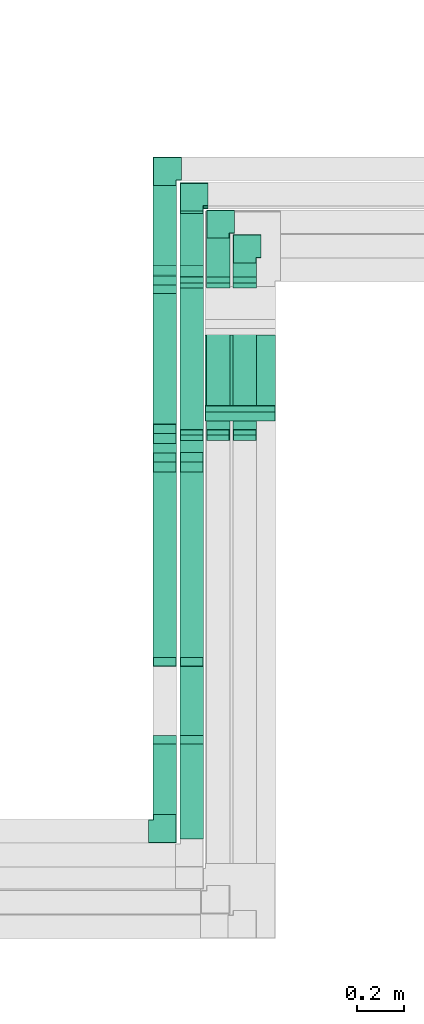
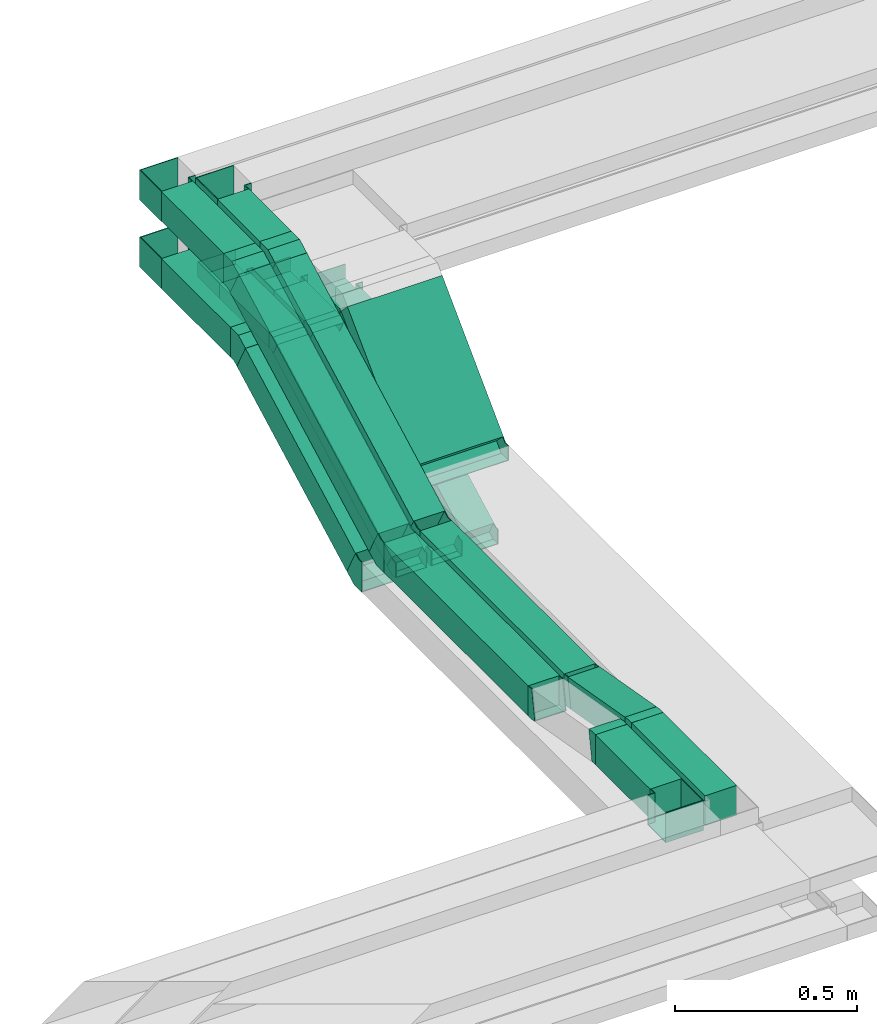
# One storey, part 11 of 18: 24 flow fittings, 18 flow segments.
"""IFC2X3 building model written with IfcOpenShell, lengths in millimetres."""

from ifc_helpers import new_model, entity, si_unit, converted_unit, derived_unit, direction, frame, frame_2d, origin, origin_2d_with_axis, place, context, subcontext, project, spatial, rectangle, extrude, faceted_brep, source, transform, mapped, material, type_object, type_shapes, element, save


model = new_model("IFC2X3")

# Units and contexts
model_context = context("Model", 3, precision=0.01, world=origin(), true_north=direction((6.12303176911189e-17, 1.0)))
body_context = subcontext(model_context, "Body", "Model", "MODEL_VIEW")
ifc_project = project(units=[si_unit("LENGTHUNIT", "METRE", prefix="MILLI"), si_unit("AREAUNIT", "SQUARE_METRE"), si_unit("VOLUMEUNIT", "CUBIC_METRE"), converted_unit("PLANEANGLEUNIT", "DEGREE", entity("IfcRatioMeasure", 0.0174532925199433), si_unit("PLANEANGLEUNIT", "RADIAN"), dimensions=[0, 0, 0, 0, 0, 0, 0]), si_unit("MASSUNIT", "GRAM", prefix="KILO"), derived_unit("MASSDENSITYUNIT", [(si_unit("MASSUNIT", "GRAM", prefix="KILO"), 1), (si_unit("LENGTHUNIT", "METRE"), -3)]), derived_unit("MOMENTOFINERTIAUNIT", [(si_unit("LENGTHUNIT", "METRE"), 4)]), si_unit("TIMEUNIT", "SECOND"), si_unit("FREQUENCYUNIT", "HERTZ"), si_unit("THERMODYNAMICTEMPERATUREUNIT", "DEGREE_CELSIUS"), derived_unit("THERMALTRANSMITTANCEUNIT", [(si_unit("MASSUNIT", "GRAM", prefix="KILO"), 1), (si_unit("THERMODYNAMICTEMPERATUREUNIT", "KELVIN"), -1), (si_unit("TIMEUNIT", "SECOND"), -3)]), derived_unit("VOLUMETRICFLOWRATEUNIT", [(si_unit("LENGTHUNIT", "METRE"), 3), (si_unit("TIMEUNIT", "SECOND"), -1)]), derived_unit("MASSFLOWRATEUNIT", [(si_unit("MASSUNIT", "GRAM", prefix="KILO"), 1), (si_unit("TIMEUNIT", "SECOND"), -1)]), derived_unit("ROTATIONALFREQUENCYUNIT", [(si_unit("TIMEUNIT", "SECOND"), -1)]), si_unit("ELECTRICCURRENTUNIT", "AMPERE"), si_unit("ELECTRICVOLTAGEUNIT", "VOLT"), si_unit("POWERUNIT", "WATT"), si_unit("FORCEUNIT", "NEWTON", prefix="KILO"), si_unit("ILLUMINANCEUNIT", "LUX"), si_unit("LUMINOUSFLUXUNIT", "LUMEN"), si_unit("LUMINOUSINTENSITYUNIT", "CANDELA"), derived_unit("USERDEFINED", [(si_unit("MASSUNIT", "GRAM", prefix="KILO"), -1), (si_unit("LENGTHUNIT", "METRE"), -2), (si_unit("TIMEUNIT", "SECOND"), 3), (si_unit("LUMINOUSFLUXUNIT", "LUMEN"), 1)]), derived_unit("LINEARVELOCITYUNIT", [(si_unit("LENGTHUNIT", "METRE"), 1), (si_unit("TIMEUNIT", "SECOND"), -1)]), si_unit("PRESSUREUNIT", "PASCAL"), derived_unit("USERDEFINED", [(si_unit("LENGTHUNIT", "METRE"), -2), (si_unit("MASSUNIT", "GRAM", prefix="KILO"), 1), (si_unit("TIMEUNIT", "SECOND"), -2)]), derived_unit("LINEARFORCEUNIT", [(si_unit("MASSUNIT", "GRAM", prefix="KILO"), 1), (si_unit("LENGTHUNIT", "METRE"), 1), (si_unit("TIMEUNIT", "SECOND"), -2), (si_unit("LENGTHUNIT", "METRE"), -1)]), derived_unit("PLANARFORCEUNIT", [(si_unit("MASSUNIT", "GRAM", prefix="KILO"), 1), (si_unit("LENGTHUNIT", "METRE"), 1), (si_unit("TIMEUNIT", "SECOND"), -2), (si_unit("LENGTHUNIT", "METRE"), -2)])], contexts=[model_context])

# Site, building, storey
site_placement = place(None, frame((0.0, -0.00077364408347762, 0.0)))
site = spatial("IfcSite", under=ifc_project, at=site_placement, CompositionType="ELEMENT")
building_placement = place(site_placement, origin())
building = spatial("IfcBuilding", under=site, at=building_placement, CompositionType="ELEMENT")
storey_placement = place(building_placement, frame((0.0, 0.0, 19800.0)))
storey = spatial("IfcBuildingStorey", under=building, at=storey_placement, CompositionType="ELEMENT", Elevation=19800.0)

# Flow segments
cable_carrier_segment_type = type_object("IfcCableCarrierSegmentType", PredefinedType="CABLETRAYSEGMENT")
flow_segment_1_placement = place(storey_placement, frame((45595.1221386505, 8738.57726519395, 2760.53094745423)))
element("IfcFlowSegment", 1, at=flow_segment_1_placement, inside=storey, type_object=cable_carrier_segment_type, context=body_context, shape_type="SweptSolid", body=[
    extrude(rectangle(XDim=100.000000000004, YDim=99.9999999999946, at=frame_2d((-2.59348098552437e-13, 0.0), x_axis=(1.0, 0.0))), frame((50.0, 23.4967105796033, 44.1350721302065), z_axis=(0.0, 0.882701442604095, 0.469934211592058), x_axis=(0.0, -0.469934211592058, 0.882701442604095)), (0.0, 0.0, 1.0), 863.244153807607),
])
flow_segment_2_placement = place(storey_placement, frame((45595.1221386505, 7913.71235144538, 2740.0)))
element("IfcFlowSegment", 2, at=flow_segment_2_placement, inside=storey, type_object=cable_carrier_segment_type, context=body_context, shape_type="SweptSolid", body=[
    extrude(rectangle(XDim=789.605024897989, YDim=99.9999999999946, at=frame_2d((5.40012479177676e-13, 0.0), x_axis=(1.0, 0.0))), frame((50.0, 394.802512448994, 0.0), z_axis=(0.0, 0.0, 1.0), x_axis=(0.0, 1.0, 0.0)), (0.0, 0.0, 1.0), 100.000000000003),
])
flow_segment_3_placement = place(storey_placement, frame((45595.1221386505, 7245.0, 2800.0)))
element("IfcFlowSegment", 3, at=flow_segment_3_placement, inside=storey, type_object=cable_carrier_segment_type, context=body_context, shape_type="SweptSolid", body=[
    extrude(rectangle(XDim=300.062822927531, YDim=99.9999999999946, at=frame_2d((0.0, -4.33075797445781e-12), x_axis=(1.0, 0.0))), frame((50.0, 150.031411463766, 0.0), z_axis=(0.0, 0.0, 1.0), x_axis=(0.0, -1.0, 0.0)), (0.0, 0.0, 1.0), 100.000000000003),
])
flow_segment_4_placement = place(storey_placement, frame((45709.2859471786, 8740.21502056394, 2761.40285865935)))
element("IfcFlowSegment", 4, at=flow_segment_4_placement, inside=storey, type_object=cable_carrier_segment_type, context=body_context, shape_type="SweptSolid", body=[
    extrude(rectangle(XDim=100.000000000004, YDim=99.9999999999946, at=origin_2d_with_axis()), frame((50.0, 23.4967105796044, 44.1350721302065), z_axis=(0.0, 0.882701442604095, 0.469934211592058), x_axis=(0.0, -0.469934211592058, 0.882701442604095)), (0.0, 0.0, 1.0), 859.53337394256),
])
flow_segment_5_placement = place(storey_placement, frame((45709.2859471786, 7913.71235144538, 2740.0)))
element("IfcFlowSegment", 5, at=flow_segment_5_placement, inside=storey, type_object=cable_carrier_segment_type, context=body_context, shape_type="SweptSolid", body=[
    extrude(rectangle(XDim=789.803925423303, YDim=99.9999999999946, at=origin_2d_with_axis()), frame((50.0, 394.901962711651, 0.0), z_axis=(0.0, 0.0, 1.0), x_axis=(0.0, 1.0, 0.0)), (0.0, 0.0, 1.0), 100.000000000003),
])
flow_segment_6_placement = place(storey_placement, frame((45709.2859471786, 7564.5375114641, 2743.22303917132)))
element("IfcFlowSegment", 6, at=flow_segment_6_placement, inside=storey, type_object=cable_carrier_segment_type, context=body_context, shape_type="SweptSolid", body=[
    extrude(rectangle(XDim=99.9999999999979, YDim=99.9999999999946, at=origin_2d_with_axis()), frame((50.0, 8.68240888334563, 104.313534006595), z_axis=(0.0, 0.984807753012211, -0.173648177666916), x_axis=(0.0, 0.173648177666916, 0.984807753012211)), (0.0, 0.0, 1.0), 317.153609648693),
])
flow_segment_7_placement = place(storey_placement, frame((45709.2859471786, 7141.9281801225, 2800.0)))
element("IfcFlowSegment", 7, at=flow_segment_7_placement, inside=storey, type_object=cable_carrier_segment_type, context=body_context, shape_type="SweptSolid", body=[
    extrude(rectangle(XDim=403.134642804848, YDim=99.9999999999946, at=frame_2d((5.40012479177676e-13, -4.33075797445781e-12), x_axis=(1.0, 0.0))), frame((50.0, 201.567321402425, 0.0), z_axis=(0.0, 0.0, 1.0), x_axis=(0.0, -1.0, 0.0)), (0.0, 0.0, 1.0), 100.000000000003),
])
flow_segment_8_placement = place(storey_placement, frame((45816.3862833309, 8951.96703386638, 2826.9669913787)))
element("IfcFlowSegment", 8, at=flow_segment_8_placement, inside=storey, type_object=cable_carrier_segment_type, context=body_context, shape_type="SweptSolid", body=[
    extrude(rectangle(XDim=50.0000000000018, YDim=300.000000000001, at=frame_2d((3.85469434149854e-13, 0.0), x_axis=(1.0, 0.0))), frame((150.000000817453, 17.6776698475757, 17.6776695619554), z_axis=(-1.65086776189245e-09, 0.707106781186548, 0.707106781186548), x_axis=(1.34656693262509e-09, -0.707106781186548, 0.707106781186548)), (0.0, 0.0, 1.0), 474.766610138279),
])
flow_segment_9_placement = place(storey_placement, frame((45595.1221386505, 9546.17952314468, 2950.0)))
element("IfcFlowSegment", 9, at=flow_segment_9_placement, inside=storey, type_object=cable_carrier_segment_type, context=body_context, shape_type="SweptSolid", body=[
    extrude(rectangle(XDim=378.820559701483, YDim=99.9999999999946, at=frame_2d((-5.40012479177676e-13, -4.33075797445781e-12), x_axis=(1.0, 0.0))), frame((50.0, 189.410279850743, 0.0), z_axis=(0.0, 0.0, 1.0), x_axis=(0.0, -1.0, 0.0)), (0.0, 0.0, 1.0), 100.000000000008),
])
flow_segment_10_placement = place(storey_placement, frame((45595.1221386505, 8860.8020535939, 2620.49048092078)))
element("IfcFlowSegment", 10, at=flow_segment_10_placement, inside=storey, type_object=cable_carrier_segment_type, context=body_context, shape_type="SweptSolid", body=[
    extrude(rectangle(XDim=100.000000000004, YDim=99.9999999999946, at=frame_2d((0.0, 0.0), x_axis=(0.0, 1.0))), frame((50.0, 23.4735781392964, 44.1473796429476), z_axis=(0.0, 0.882947592858917, 0.469471562785909), x_axis=(-1.0, 0.0, 0.0)), (0.0, 0.0, 1.0), 683.160183269278),
])
flow_segment_11_placement = place(storey_placement, frame((45709.2859471785, 9533.71312300239, 2950.0)))
element("IfcFlowSegment", 11, at=flow_segment_11_placement, inside=storey, type_object=cable_carrier_segment_type, context=body_context, shape_type="SweptSolid", body=[
    extrude(rectangle(XDim=271.286959843684, YDim=99.9999999999946, at=origin_2d_with_axis()), frame((50.0, 135.643479921847, 0.0), z_axis=(0.0, 0.0, 1.0), x_axis=(0.0, 1.0, 0.0)), (0.0, 0.0, 1.0), 49.9999999999973),
])
flow_segment_12_placement = place(storey_placement, frame((45709.2859471786, 8861.53166466641, 2611.71155038525)))
element("IfcFlowSegment", 12, at=flow_segment_12_placement, inside=storey, type_object=cable_carrier_segment_type, context=body_context, shape_type="SweptSolid", body=[
    extrude(rectangle(XDim=49.9999999999982, YDim=708.092983553467, at=frame_2d((0.0, 0.0), x_axis=(0.0, 1.0))), frame((0.0, 324.341286744055, 188.288449614771), z_axis=(1.0, 0.0, 0.0), x_axis=(0.0, 0.882947592858905, 0.469471562785931)), (0.0, 0.0, 1.0), 99.9999999999946),
])
flow_segment_13_placement = place(storey_placement, frame((45821.4991593832, 8861.53166466642, 2611.71155038525)))
element("IfcFlowSegment", 13, at=flow_segment_13_placement, inside=storey, type_object=cable_carrier_segment_type, context=body_context, shape_type="SweptSolid", body=[
    extrude(rectangle(XDim=49.9999999999971, YDim=708.092983553457, at=frame_2d((-1.02318153949454e-12, -1.91313631603407e-12), x_axis=(0.0, 1.0))), frame((0.0, 324.341286744052, 188.288449614767), z_axis=(1.0, 0.0, 0.0), x_axis=(0.0, 0.882947592858912, 0.46947156278592)), (0.0, 0.0, 1.0), 99.9999999999945),
])
flow_segment_14_placement = place(storey_placement, frame((45821.4991593831, 9533.71312300239, 2950.0)))
element("IfcFlowSegment", 14, at=flow_segment_14_placement, inside=storey, type_object=cable_carrier_segment_type, context=body_context, shape_type="SweptSolid", body=[
    extrude(rectangle(XDim=166.286959843394, YDim=99.9999999999946, at=frame_2d((5.40012479177676e-13, -4.33075797445781e-12), x_axis=(1.0, 0.0))), frame((50.0, 83.1434799217, 0.0), z_axis=(0.0, 0.0, 1.0), x_axis=(0.0, -1.0, 0.0)), (0.0, 0.0, 1.0), 50.0000000000016),
])
flow_segment_15_placement = place(storey_placement, frame((45934.7609870451, 8861.53166466642, 2611.71155038525)))
element("IfcFlowSegment", 15, at=flow_segment_15_placement, inside=storey, type_object=cable_carrier_segment_type, context=body_context, shape_type="SweptSolid", body=[
    extrude(rectangle(XDim=49.9999999999977, YDim=708.09298355346, at=frame_2d((0.0, 0.0), x_axis=(0.0, 1.0))), frame((0.0, 324.341286744055, 188.288449614763), z_axis=(1.0, 0.0, 0.0), x_axis=(0.0, 0.882947592858916, 0.469471562785912)), (0.0, 0.0, 1.0), 99.9999999999946),
])
flow_segment_16_placement = place(storey_placement, frame((45934.7609870451, 9533.7131230024, 2950.0)))
element("IfcFlowSegment", 16, at=flow_segment_16_placement, inside=storey, type_object=cable_carrier_segment_type, context=body_context, shape_type="SweptSolid", body=[
    extrude(rectangle(XDim=61.2869598436415, YDim=99.9999999999946, at=frame_2d((5.40012479177676e-13, 0.0), x_axis=(1.0, 0.0))), frame((50.0, 30.6434799218213, 0.0), z_axis=(0.0, 0.0, 1.0), x_axis=(0.0, -1.0, 0.0)), (0.0, 0.0, 1.0), 49.9999999999973),
])
flow_segment_17_placement = place(storey_placement, frame((45595.1221386505, 9582.81743508927, 3175.0)))
element("IfcFlowSegment", 17, at=flow_segment_17_placement, inside=storey, type_object=cable_carrier_segment_type, context=body_context, shape_type="SweptSolid", body=[
    extrude(rectangle(XDim=342.182647756361, YDim=99.9999999999946, at=frame_2d((-5.40012479177676e-13, 0.0), x_axis=(1.0, 0.0))), frame((50.0, 171.091323878181, 0.0), z_axis=(0.0, 0.0, 1.0), x_axis=(0.0, -1.0, 0.0)), (0.0, 0.0, 1.0), 100.000000000003),
])
flow_segment_18_placement = place(storey_placement, frame((45709.2859471786, 9582.61853436311, 3175.0)))
element("IfcFlowSegment", 18, at=flow_segment_18_placement, inside=storey, type_object=cable_carrier_segment_type, context=body_context, shape_type="SweptSolid", body=[
    extrude(rectangle(XDim=233.381537551787, YDim=99.9999999999946, at=frame_2d((-5.40012479177676e-13, 0.0), x_axis=(1.0, 0.0))), frame((50.0000001264069, 116.690769123244, 3.42125372299051e-07), z_axis=(0.0, -2.93187893227309e-09, 1.0), x_axis=(-1.08328686606349e-09, -1.0, -2.93187893227309e-09)), (0.0, 0.0, 1.0), 100.000000000008),
])

# Flow fittings
ifc_material = material()
cable_carrier_fitting_type_1 = type_object("IfcCableCarrierFittingType", PredefinedType="NOTDEFINED", material=ifc_material)
shared_shape_1 = source(origin(), body_context, "Body", "Brep", [
    faceted_brep([(-70.0, 50.0, -25.0), (-70.0, -50.0, -25.0), (-70.0, -50.0, 25.0), (-70.0, -47.4600000101598, 25.0), (-70.0, -47.4600000101598, -22.4600000101565), (-70.0, 47.4600000101602, -22.4600000101565), (-70.0, 47.4600000101602, 25.0), (-70.0, 50.0, 25.0), (-50.0, 50.0, -25.0), (-50.0, 70.0, -25.0), (50.0, 70.0, -25.0), (50.0, -50.0, -25.0), (50.0, -50.0, 25.0), (50.0, 70.0, 25.0), (47.4600000101603, 70.0, 25.0), (47.4600000101596, -47.4600000101602, 25.0), (47.4600000101596, -47.4600000101602, -22.4600000101565), (47.4600000101603, 70.0, -22.4600000101565), (-47.4600000101597, 70.0, -22.4600000101565), (-47.4600000101602, 47.4600000101602, -22.4600000101565), (-47.4600000101602, 47.4600000101602, 25.0), (-47.4600000101597, 70.0, 25.0), (-50.0, 70.0, 25.0), (-50.0, 50.0, 25.0)], [[[0, 1, 2, 3, 4, 5, 6, 7]], [[1, 0, 8, 9, 10, 11]], [[2, 1, 11, 12]], [[3, 2, 12, 13, 14, 15]], [[4, 3, 15, 16]], [[5, 4, 16, 17, 18, 19]], [[6, 5, 19, 20]], [[7, 6, 20, 21, 22, 23]], [[0, 7, 23, 8]], [[9, 22, 21, 18, 17, 14, 13, 10]], [[12, 11, 10, 13]], [[16, 15, 14, 17]], [[20, 19, 18, 21]], [[8, 23, 22, 9]]]),
])
type_shapes(cable_carrier_fitting_type_1, [shared_shape_1])
for number, where, z_axis, x_axis in (
    (19, (45759.2859471785, 9875.00008284607, 2975.0), (0.0, 0.0, 1.0), (-1.0, 0.0, 0.0)),
    (20, (45871.4991593832, 9770.00008284579, 2975.0), (0.0, 0.0, 1.0), (-1.0, 0.0, 0.0)),
    (21, (45984.7609870451, 9665.00008284605, 2975.0), (0.0, 0.0, 1.0), (-1.0, 0.0, 0.0)),
):
    element("IfcFlowFitting", number, at=place(storey_placement, frame(where, z_axis=z_axis, x_axis=x_axis)), inside=storey, type_object=cable_carrier_fitting_type_1, material=ifc_material, context=body_context, shape_type="MappedRepresentation", body=[
        mapped(shared_shape_1, transform((0.0, 0.0, 0.0), scale=1.0)),
    ])
cable_carrier_fitting_type_2 = type_object("IfcCableCarrierFittingType", PredefinedType="NOTDEFINED", material=ifc_material)
shared_shape_2 = source(origin(), body_context, "Body", "Brep", [
    faceted_brep([(-70.0, 50.0, -50.0), (-70.0, -50.0, -50.0), (-70.0, -50.0, 50.0), (-70.0, -47.4600000101598, 50.0), (-70.0, -47.4600000101598, -47.4600000101565), (-70.0, 47.4600000101602, -47.4600000101565), (-70.0, 47.4600000101602, 50.0), (-70.0, 50.0, 50.0), (-50.0, 50.0, -50.0), (-50.0, 70.0, -50.0), (50.0, 70.0, -50.0), (50.0, -50.0, -50.0), (50.0, -50.0, 50.0), (50.0, 70.0, 50.0), (47.4600000101603, 70.0, 50.0), (47.4600000101596, -47.4600000101602, 50.0), (47.4600000101596, -47.4600000101602, -47.4600000101565), (47.4600000101603, 70.0, -47.4600000101565), (-47.4600000101597, 70.0, -47.4600000101565), (-47.4600000101602, 47.4600000101602, -47.4600000101565), (-47.4600000101602, 47.4600000101602, 50.0), (-47.4600000101597, 70.0, 50.0), (-50.0, 70.0, 50.0), (-50.0, 50.0, 50.0)], [[[0, 1, 2, 3, 4, 5, 6, 7]], [[1, 0, 8, 9, 10, 11]], [[2, 1, 11, 12]], [[3, 2, 12, 13, 14, 15]], [[4, 3, 15, 16]], [[5, 4, 16, 17, 18, 19]], [[6, 5, 19, 20]], [[7, 6, 20, 21, 22, 23]], [[0, 7, 23, 8]], [[9, 22, 21, 18, 17, 14, 13, 10]], [[12, 11, 10, 13]], [[16, 15, 14, 17]], [[20, 19, 18, 21]], [[8, 23, 22, 9]]]),
])
type_shapes(cable_carrier_fitting_type_2, [shared_shape_2])
flow_fitting_1_placement = place(storey_placement, frame((45645.1221386505, 7175.0, 2850.0)))
element("IfcFlowFitting", 22, at=flow_fitting_1_placement, inside=storey, type_object=cable_carrier_fitting_type_2, material=ifc_material, context=body_context, shape_type="MappedRepresentation", body=[
    mapped(shared_shape_2, transform((0.0, 0.0, 0.0), scale=1.0)),
])
for number, where, z_axis, x_axis in (
    (23, (45645.1221386505, 9995.00008284615, 3000.0), (0.0, 0.0, 1.0), (-1.0, 0.0, 0.0)),
    (24, (45645.1221386505, 9995.00008284562, 3225.0), (0.0, 0.0, 1.0), (-1.0, 0.0, 0.0)),
    (25, (45759.2859474314, 9886.00007211565, 3225.0), (0.0, 0.0, 1.0), (-1.0, 0.0, 0.0)),
):
    element("IfcFlowFitting", number, at=place(storey_placement, frame(where, z_axis=z_axis, x_axis=x_axis)), inside=storey, type_object=cable_carrier_fitting_type_2, material=ifc_material, context=body_context, shape_type="MappedRepresentation", body=[
        mapped(shared_shape_2, transform((0.0, 0.0, 0.0), scale=1.0)),
    ])
cable_carrier_fitting_type_3 = type_object("IfcCableCarrierFittingType", PredefinedType="NOTDEFINED", material=ifc_material)
shared_shape_3 = source(origin(), body_context, "Body", "Brep", [
    faceted_brep([(-14.1863096702256, -50.0, 50.0), (-14.1863096702253, 50.0, 50.0), (-14.1863096702253, 50.0, 47.4600000101635), (-14.1863096702256, -47.4600000101599, 47.4600000101635), (-14.1863096702256, -47.4600000101599, -47.4600000101565), (-14.1863096702253, 50.0, -47.4600000101565), (-14.1863096702253, 50.0, -50.0), (-14.1863096702256, -50.0, -50.0), (22.6531966332208, -46.7769608285558, 50.0), (22.6531966332208, -46.7769608285557, -50.0), (5.28837886652064, 51.7038144726638, -50.0), (5.28837886652063, 51.7038144726638, -47.4600000101565), (22.2121302637108, -44.2755491459104, -47.4600000101565), (22.2121302637108, -44.2755491459104, 47.4600000101635), (5.28837886652064, 51.7038144726638, 47.4600000101635), (5.28837886652063, 51.7038144726638, 50.0), (4.37443317629835, -50.0, 50.0), (-4.3744331762976, 50.0, 50.0), (-4.3744331762976, 50.0, 47.4600000101635), (4.15221197183126, -47.46000001016, 47.4600000101635), (4.15221197183126, -47.46000001016, -47.4600000101565), (-4.3744331762976, 50.0, -47.4600000101565), (-4.3744331762976, 50.0, -50.0), (4.37443317629831, -50.0, -50.0)], [[[0, 1, 2, 3, 4, 5, 6, 7]], [[8, 9, 10, 11, 12, 13, 14, 15]], [[1, 0, 16, 8, 15, 17]], [[2, 1, 17, 18]], [[3, 2, 18, 14, 13, 19]], [[4, 3, 19, 20]], [[5, 4, 20, 12, 11, 21]], [[6, 5, 21, 22]], [[7, 6, 22, 10, 9, 23]], [[0, 7, 23, 16]], [[18, 17, 15, 14]], [[20, 19, 13, 12]], [[22, 21, 11, 10]], [[16, 23, 9, 8]]]),
])
type_shapes(cable_carrier_fitting_type_3, [shared_shape_3])
for number, where, z_axis, x_axis in (
    (26, (45645.1221386505, 7899.52604177516, 2790.0), (-1.0, 0.0, 0.0), (0.0, -1.0, 0.0)),
    (27, (45645.1221386505, 7559.24913259761, 2850.0), (1.0, 0.0, 0.0), (0.0, -0.984807753012209, 0.173648177666924)),
    (28, (45759.2859471786, 7899.52604177516, 2790.0), (-1.0, 0.0, 0.0), (0.0, -1.0, 0.0)),
    (29, (45759.2859471786, 7559.24913259757, 2850.0), (1.0, 0.0, 0.0), (0.0, -0.984807753012209, 0.173648177666924)),
):
    element("IfcFlowFitting", number, at=place(storey_placement, frame(where, z_axis=z_axis, x_axis=x_axis)), inside=storey, type_object=cable_carrier_fitting_type_3, material=ifc_material, context=body_context, shape_type="MappedRepresentation", body=[
        mapped(shared_shape_3, transform((0.0, 0.0, 0.0), scale=1.0)),
    ])
cable_carrier_fitting_type_4 = type_object("IfcCableCarrierFittingType", PredefinedType="NOTDEFINED", material=ifc_material)
shared_shape_4 = source(origin(), body_context, "Body", "Brep", [
    faceted_brep([(-27.7817459305236, -25.0, 150.0), (-27.7817459305234, 25.0, 150.0), (-27.7817459305234, 25.0, 147.460000010164), (-27.7817459305236, -22.4600000101599, 147.460000010164), (-27.7817459305236, -22.4600000101599, -147.460000010156), (-27.7817459305234, 25.0, -147.460000010156), (-27.7817459305234, 25.0, -150.0), (-27.7817459305236, -25.0, -150.0), (37.3223304703394, 1.96699141101549, 150.0), (37.3223304703394, 1.96699141101549, -150.0), (1.96699141100793, 37.3223304703388, -150.0), (1.96699141100793, 37.3223304703388, -147.460000010156), (35.5262792533096, 3.76304262804491, -147.460000010156), (35.5262792533096, 3.76304262804491, 147.460000010164), (1.96699141100793, 37.3223304703388, 147.460000010164), (1.96699141100793, 37.3223304703388, 150.0), (10.3553390593296, -25.0, 150.0), (-10.3553390593287, 25.0, 150.0), (-10.3553390593287, 25.0, 147.460000010164), (9.30323661510995, -22.46000001016, 147.460000010164), (9.30323661510995, -22.46000001016, -147.460000010156), (-10.3553390593287, 25.0, -147.460000010156), (-10.3553390593287, 25.0, -150.0), (10.3553390593294, -25.0, -150.0)], [[[0, 1, 2, 3, 4, 5, 6, 7]], [[8, 9, 10, 11, 12, 13, 14, 15]], [[1, 0, 16, 8, 15, 17]], [[2, 1, 17, 18]], [[3, 2, 18, 14, 13, 19]], [[4, 3, 19, 20]], [[5, 4, 20, 12, 11, 21]], [[6, 5, 21, 22]], [[7, 6, 22, 10, 9, 23]], [[0, 7, 23, 16]], [[18, 17, 15, 14]], [[20, 19, 13, 12]], [[22, 21, 11, 10]], [[16, 23, 9, 8]]]),
])
type_shapes(cable_carrier_fitting_type_4, [shared_shape_4])
flow_fitting_2_placement = place(storey_placement, frame((45966.3862841484, 8950.00004277328, 2825.0), z_axis=(-1.0, 0.0, 0.0), x_axis=(0.0, -0.707106781186535, -0.70710678118656)))
element("IfcFlowFitting", 30, at=flow_fitting_2_placement, inside=storey, type_object=cable_carrier_fitting_type_4, material=ifc_material, context=body_context, shape_type="MappedRepresentation", body=[
    mapped(shared_shape_4, transform((0.0, 0.0, 0.0), scale=1.0)),
])
cable_carrier_fitting_type_5 = type_object("IfcCableCarrierFittingType", PredefinedType="NOTDEFINED", material=ifc_material)
shared_shape_5 = source(origin(), body_context, "Body", "Brep", [
    faceted_brep([(-31.1794402985367, -50.0, 50.0), (-31.1794402985364, 50.0, 50.0), (-31.1794402985364, 50.0, 47.4600000101635), (-31.1794402985367, -47.4600000101599, 47.4600000101635), (-31.1794402985367, -47.4600000101599, -47.4600000101565), (-31.1794402985364, 50.0, -47.4600000101565), (-31.1794402985364, 50.0, -50.0), (-31.1794402985367, -50.0, -50.0), (51.0033898975785, -29.5095190792005, 50.0), (51.0033898975785, -29.5095190792005, -50.0), (4.0562336189847, 58.7852402066897, -50.0), (4.0562336189847, 58.7852402066897, -47.4600000101565), (49.810932132872, -27.2668322023097, -47.4600000101565), (49.810932132872, -27.2668322023097, 47.4600000101635), (4.05623361898471, 58.7852402066897, 47.4600000101635), (4.0562336189847, 58.7852402066897, 50.0), (12.4664001421608, -50.0, 50.0), (-12.46640014216, 50.0, 50.0), (-12.46640014216, 50.0, 47.4600000101635), (11.8331070174721, -47.46000001016, 47.4600000101635), (11.8331070174721, -47.46000001016, -47.4600000101565), (-12.46640014216, 50.0, -47.4600000101565), (-12.46640014216, 50.0, -50.0), (12.4664001421607, -50.0, -50.0)], [[[0, 1, 2, 3, 4, 5, 6, 7]], [[8, 9, 10, 11, 12, 13, 14, 15]], [[1, 0, 16, 8, 15, 17]], [[2, 1, 17, 18]], [[3, 2, 18, 14, 13, 19]], [[4, 3, 19, 20]], [[5, 4, 20, 12, 11, 21]], [[6, 5, 21, 22]], [[7, 6, 22, 10, 9, 23]], [[0, 7, 23, 16]], [[18, 17, 15, 14]], [[20, 19, 13, 12]], [[22, 21, 11, 10]], [[16, 23, 9, 8]]]),
])
type_shapes(cable_carrier_fitting_type_5, [shared_shape_5])
for number, where, z_axis, x_axis in (
    (31, (45645.1221386505, 8856.74581997491, 2650.0), (1.0, 0.0, 0.0), (0.0, 1.0, 0.0)),
    (32, (45645.1221386505, 9515.00008284615, 3000.0), (1.0, 0.0, 0.0), (0.0, -1.0, 0.0)),
):
    element("IfcFlowFitting", number, at=place(storey_placement, frame(where, z_axis=z_axis, x_axis=x_axis)), inside=storey, type_object=cable_carrier_fitting_type_5, material=ifc_material, context=body_context, shape_type="MappedRepresentation", body=[
        mapped(shared_shape_5, transform((0.0, 0.0, 0.0), scale=1.0)),
    ])
cable_carrier_fitting_type_6 = type_object("IfcCableCarrierFittingType", PredefinedType="NOTDEFINED", material=ifc_material)
shared_shape_6 = source(origin(), body_context, "Body", "Brep", [
    faceted_brep([(-18.7130401563762, -25.0, 50.0), (-18.713040156376, 25.0, 50.0), (-18.713040156376, 25.0, 47.4600000101635), (-18.7130401563762, -22.4600000101599, 47.4600000101635), (-18.7130401563762, -22.4600000101599, -47.4600000101565), (-18.713040156376, 25.0, -47.4600000101565), (-18.713040156376, 25.0, -50.0), (-18.7130401563762, -25.0, -50.0), (28.2594228307936, -13.2884496147829, 50.0), (28.2594228307936, -13.2884496147829, -50.0), (4.78584469149672, 30.8589300281622, -50.0), (4.78584469149673, 30.8589300281622, -47.4600000101565), (27.0669650660872, -11.045762737892, -47.4600000101565), (27.0669650660872, -11.045762737892, 47.4600000101635), (4.78584469149672, 30.8589300281622, 47.4600000101635), (4.78584469149673, 30.8589300281622, 50.0), (6.23320007108065, -25.0, 50.0), (-6.23320007107984, 25.0, 50.0), (-6.23320007107984, 25.0, 47.4600000101635), (5.59990694639196, -22.46000001016, 47.4600000101635), (5.59990694639196, -22.46000001016, -47.4600000101565), (-6.23320007107984, 25.0, -47.4600000101565), (-6.23320007107984, 25.0, -50.0), (6.23320007108053, -25.0, -50.0)], [[[0, 1, 2, 3, 4, 5, 6, 7]], [[8, 9, 10, 11, 12, 13, 14, 15]], [[1, 0, 16, 8, 15, 17]], [[2, 1, 17, 18]], [[3, 2, 18, 14, 13, 19]], [[4, 3, 19, 20]], [[5, 4, 20, 12, 11, 21]], [[6, 5, 21, 22]], [[7, 6, 22, 10, 9, 23]], [[0, 7, 23, 16]], [[18, 17, 15, 14]], [[20, 19, 13, 12]], [[22, 21, 11, 10]], [[16, 23, 9, 8]]]),
])
type_shapes(cable_carrier_fitting_type_6, [shared_shape_6])
for number, where, z_axis, x_axis in (
    (33, (45759.2859471786, 9515.00008284602, 2975.0), (-1.0, 0.0, 0.0), (0.0, 0.882947592858903, 0.469471562785936)),
    (34, (45759.2859471786, 8856.74581997492, 2625.0), (-1.0, 0.0, 0.0), (0.0, -0.882947592858904, -0.469471562785934)),
    (35, (45871.4991593832, 8856.74581997492, 2625.0), (-1.0, 0.0, 0.0), (0.0, -0.882947592858907, -0.469471562785928)),
    (36, (45871.4991593832, 9515.00008284601, 2975.0), (-1.0, 0.0, 0.0), (0.0, 0.88294759285891, 0.469471562785922)),
    (37, (45984.7609870451, 8856.74581997492, 2625.0), (-1.0, 0.0, 0.0), (0.0, -0.882947592858912, -0.469471562785918)),
    (38, (45984.7609870451, 9515.00008284602, 2975.0), (-1.0, 0.0, 0.0), (0.0, 0.882947592858915, 0.469471562785914)),
):
    element("IfcFlowFitting", number, at=place(storey_placement, frame(where, z_axis=z_axis, x_axis=x_axis)), inside=storey, type_object=cable_carrier_fitting_type_6, material=ifc_material, context=body_context, shape_type="MappedRepresentation", body=[
        mapped(shared_shape_6, transform((0.0, 0.0, 0.0), scale=1.0)),
    ])
cable_carrier_fitting_type_7 = type_object("IfcCableCarrierFittingType", PredefinedType="NOTDEFINED", material=ifc_material)
shared_shape_7 = source(origin(), body_context, "Body", "Brep", [
    faceted_brep([(-31.208665431794, -50.0, 50.0), (-31.2086654317937, 50.0, 50.0), (-31.2086654317937, 50.0, 47.4600000101635), (-31.208665431794, -47.4600000101599, 47.4600000101635), (-31.208665431794, -47.4600000101599, -47.4600000101565), (-31.2086654317937, 50.0, -47.4600000101565), (-31.2086654317937, 50.0, -50.0), (-31.208665431794, -50.0, -50.0), (51.0446445779971, -29.4690525456742, 50.0), (51.0446445779971, -29.4690525456742, -50.0), (4.05122341879044, 58.8010917147349, -50.0), (4.05122341879043, 58.8010917147349, -47.4600000101565), (49.8510116853277, -27.226990890428, -47.4600000101565), (49.8510116853277, -27.226990890428, 47.4600000101635), (4.05122341879044, 58.8010917147349, 47.4600000101635), (4.05122341879044, 58.8010917147349, 50.0), (12.4803168722833, -50.0, 50.0), (-12.4803168722825, 50.0, 50.0), (-12.4803168722825, 50.0, 47.4600000101635), (11.8463167777072, -47.46000001016, 47.4600000101635), (11.8463167777072, -47.46000001016, -47.4600000101565), (-12.4803168722825, 50.0, -47.4600000101565), (-12.4803168722825, 50.0, -50.0), (12.4803168722832, -50.0, -50.0)], [[[0, 1, 2, 3, 4, 5, 6, 7]], [[8, 9, 10, 11, 12, 13, 14, 15]], [[1, 0, 16, 8, 15, 17]], [[2, 1, 17, 18]], [[3, 2, 18, 14, 13, 19]], [[4, 3, 19, 20]], [[5, 4, 20, 12, 11, 21]], [[6, 5, 21, 22]], [[7, 6, 22, 10, 9, 23]], [[0, 7, 23, 16]], [[18, 17, 15, 14]], [[20, 19, 13, 12]], [[22, 21, 11, 10]], [[16, 23, 9, 8]]]),
])
type_shapes(cable_carrier_fitting_type_7, [shared_shape_7])
for number, where, z_axis, x_axis in (
    (39, (45645.1221386505, 9551.60876965747, 3225.0), (1.0, 0.0, 0.0), (0.0, -1.0, 0.0)),
    (40, (45645.1221386505, 8734.52604177516, 2790.0), (1.0, 0.0, 0.0), (0.0, 1.0, 0.0)),
):
    element("IfcFlowFitting", number, at=place(storey_placement, frame(where, z_axis=z_axis, x_axis=x_axis)), inside=storey, type_object=cable_carrier_fitting_type_7, material=ifc_material, context=body_context, shape_type="MappedRepresentation", body=[
        mapped(shared_shape_7, transform((0.0, 0.0, 0.0), scale=1.0)),
    ])
cable_carrier_fitting_type_8 = type_object("IfcCableCarrierFittingType", PredefinedType="NOTDEFINED", material=ifc_material)
shared_shape_8 = source(origin(), body_context, "Body", "Brep", [
    faceted_brep([(-32.1030886396693, -50.0, 50.0), (-32.103088639669, 50.0, 50.0), (-32.103088639669, 50.0, 47.4600000101635), (-32.1030886396693, -47.4600000101599, 47.4600000101635), (-32.1030886396693, -47.4600000101599, -47.4600000101565), (-32.103088639669, 50.0, -47.4600000101565), (-32.103088639669, 50.0, -50.0), (-32.1030886396693, -50.0, -50.0), (52.2924215302594, -28.2154381626128, 50.0), (52.2924215302594, -28.2154381626128, -50.0), (3.89230974013119, 59.29129974198, -50.0), (3.89230974013118, 59.29129974198, -47.4600000101565), (51.0630586957076, -25.9927670287269, -47.4600000101565), (51.0630586957076, -25.9927670287269, 47.4600000101635), (3.89230974013119, 59.29129974198, 47.4600000101635), (3.89230974013119, 59.29129974198, 50.0), (12.9062326855573, -50.0, 50.0), (-12.9062326855565, 50.0, 50.0), (-12.9062326855565, 50.0, 47.4600000101635), (12.2505960677534, -47.46000001016, 47.4600000101635), (12.2505960677534, -47.46000001016, -47.4600000101565), (-12.9062326855565, 50.0, -47.4600000101565), (-12.9062326855565, 50.0, -50.0), (12.9062326855572, -50.0, -50.0)], [[[0, 1, 2, 3, 4, 5, 6, 7]], [[8, 9, 10, 11, 12, 13, 14, 15]], [[1, 0, 16, 8, 15, 17]], [[2, 1, 17, 18]], [[3, 2, 18, 14, 13, 19]], [[4, 3, 19, 20]], [[5, 4, 20, 12, 11, 21]], [[6, 5, 21, 22]], [[7, 6, 22, 10, 9, 23]], [[0, 7, 23, 16]], [[18, 17, 15, 14]], [[20, 19, 13, 12]], [[22, 21, 11, 10]], [[16, 23, 9, 8]]]),
])
type_shapes(cable_carrier_fitting_type_8, [shared_shape_8])
for number, where, z_axis, x_axis in (
    (41, (45759.2859471786, 9550.5154459242, 3225.0), (1.0, 0.0, 0.0), (0.0, -1.0, 0.0)),
    (42, (45759.2859471786, 8735.61936550835, 2790.0), (1.0, 0.0, 0.0), (0.0, 1.0, 0.0)),
):
    element("IfcFlowFitting", number, at=place(storey_placement, frame(where, z_axis=z_axis, x_axis=x_axis)), inside=storey, type_object=cable_carrier_fitting_type_8, material=ifc_material, context=body_context, shape_type="MappedRepresentation", body=[
        mapped(shared_shape_8, transform((0.0, 0.0, 0.0), scale=1.0)),
    ])

save(model, "model.ifc")
